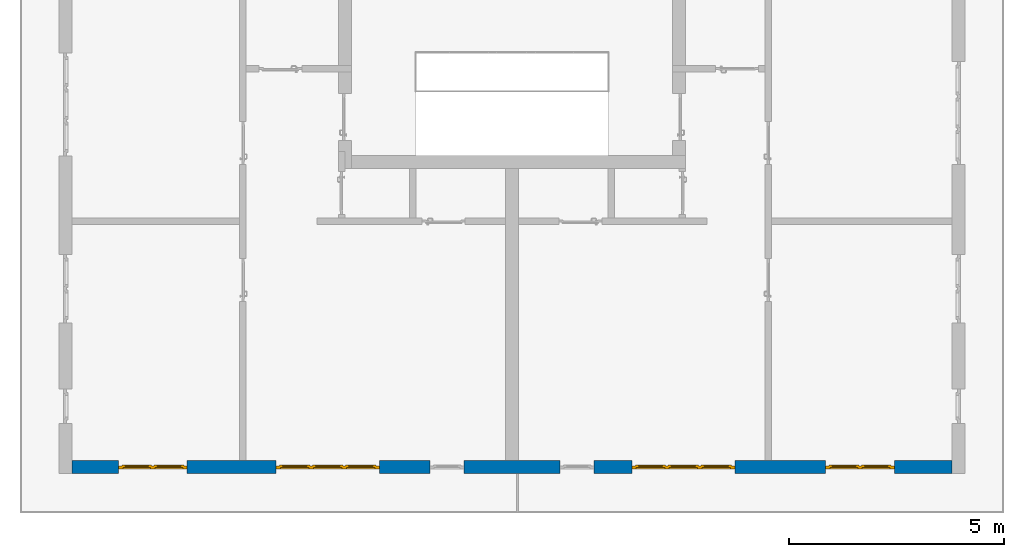
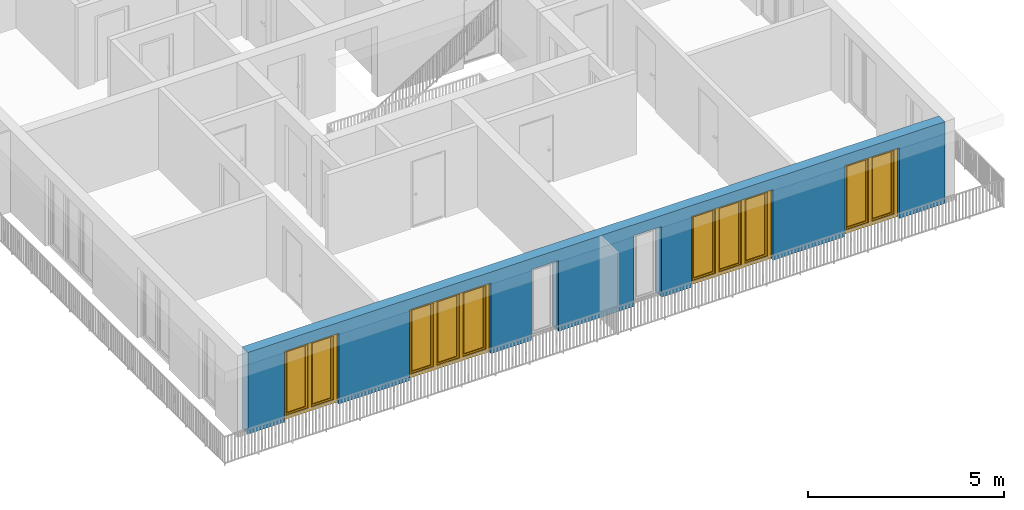
# One storey, part 9 of 54: 4 windows, 1 wall, 6 openings.
"""IFC4 building model written with IfcOpenShell, lengths in metres."""

from ifc_helpers import new_model, entity, si_unit, converted_unit, derived_unit, direction, frame, origin_with_axes, place, context, subcontext, project, spatial, polygons, source, transform, mapped, material, type_object, element, fill, save


model = new_model("IFC4")

# Units and contexts
model_context = context("Model", 3, precision=1e-05, world=origin_with_axes(), true_north=direction((0.0, 1.0)))
body_context = subcontext(model_context, "Body", "Model", "MODEL_VIEW")
ifc_project = project(units=[si_unit("LENGTHUNIT", "METRE"), si_unit("AREAUNIT", "SQUARE_METRE"), si_unit("VOLUMEUNIT", "CUBIC_METRE"), converted_unit("PLANEANGLEUNIT", "DEGREE", entity("IfcPlaneAngleMeasure", 0.0174532925199), si_unit("PLANEANGLEUNIT", "RADIAN"), dimensions=[0, 0, 0, 0, 0, 0, 0]), converted_unit("TIMEUNIT", "Year", entity("IfcTimeMeasure", 31556926.0), si_unit("TIMEUNIT", "SECOND"), dimensions=[0, 0, 1, 0, 0, 0, 0]), si_unit("MASSUNIT", "GRAM", prefix="KILO"), si_unit("THERMODYNAMICTEMPERATUREUNIT", "DEGREE_CELSIUS"), si_unit("LUMINOUSINTENSITYUNIT", "LUMEN"), si_unit("ENERGYUNIT", "JOULE", prefix="MEGA"), derived_unit("THERMALCONDUCTANCEUNIT", [(si_unit("POWERUNIT", "WATT"), 1), (si_unit("LENGTHUNIT", "METRE"), -1), (si_unit("THERMODYNAMICTEMPERATUREUNIT", "KELVIN"), -1)]), derived_unit("SPECIFICHEATCAPACITYUNIT", [(si_unit("ENERGYUNIT", "JOULE"), 1), (si_unit("MASSUNIT", "GRAM", prefix="KILO"), -1), (si_unit("THERMODYNAMICTEMPERATUREUNIT", "KELVIN"), -1)]), derived_unit("MASSDENSITYUNIT", [(si_unit("MASSUNIT", "GRAM", prefix="KILO"), 1), (si_unit("VOLUMEUNIT", "CUBIC_METRE"), -1)])], contexts=[model_context])

# Site, building, storey
site_placement = place(None, origin_with_axes())
site = spatial("IfcSite", under=ifc_project, at=site_placement, CompositionType="ELEMENT")
building_placement = place(site_placement, origin_with_axes())
building = spatial("IfcBuilding", under=site, at=building_placement, CompositionType="ELEMENT")
storey_placement = place(building_placement, frame((0.0, 0.0, 6.29), z_axis=(0.0, 0.0, 1.0), x_axis=(1.0, 0.0, 0.0)))
storey = spatial("IfcBuildingStorey", under=building, at=storey_placement, Name="2. Geschoss", CompositionType="ELEMENT", Elevation=6.29)

# Wall, openings, windows
ifc_material = material()
wall_type = type_object("IfcWallType", Name="300", PredefinedType="NOTDEFINED")
wall_placement = place(storey_placement, frame((9.3378006196, -9.92881223104, 0.0), z_axis=(0.0, 0.0, 1.0), x_axis=(-1.0, 0.0, 0.0)))
wall = element("IfcWall", 1, at=wall_placement, inside=storey, type_object=wall_type, material=ifc_material, Name="Wand-001", PredefinedType="NOTDEFINED", context=body_context, shape_type="Tessellation", body=[
    polygons([(12.4515538751, -0.3, 2.2), (12.4515538751, -0.3, 0.0), (13.63, -0.3, 0.0), (13.63, -0.3, 2.2), (16.03, -0.3, 2.2), (16.03, -0.3, 0.0), (18.0998837323, -0.3, 0.0), (18.0998837323, -0.3, 2.2), (19.6998837323, -0.3, 2.2), (19.6998837323, -0.3, 0.0), (20.78, -0.3, 0.0), (20.78, -0.3, 2.54), (0.3, -0.3, 2.54), (0.3, -0.3, 0.0), (1.6378225413, -0.3, 0.0), (1.6378225413, -0.3, 2.2), (3.2378225413, -0.3, 2.2), (3.2378225413, -0.3, 0.0), (5.35, -0.3, 0.0), (5.35, -0.3, 2.2), (7.75, -0.3, 2.2), (7.75, -0.3, 0.0), (8.62617854928, -0.3, 0.0), (8.62617854928, -0.3, 2.2), (9.42617854928, -0.3, 2.2), (9.42617854928, -0.3, 0.0), (11.6515538751, -0.3, 0.0), (11.6515538751, -0.3, 2.2), (12.4515538751, -0.1, 0.0), (12.4515538751, 0.0, 2.2), (12.4515538751, 0.0, 0.0), (13.63, 0.0, 0.0), (13.63, 0.0, 2.2), (16.03, 0.0, 2.2), (16.03, 0.0, 0.0), (18.0998837323, 0.0, 0.0), (18.0998837323, 0.0, 2.2), (19.6998837323, 0.0, 2.2), (19.6998837323, 0.0, 0.0), (20.78, 0.0, 0.0), (20.78, 0.0, 2.54), (0.3, 0.0, 2.54), (0.3, 0.0, 0.0), (1.6378225413, 0.0, 0.0), (1.6378225413, 0.0, 2.2), (3.2378225413, 0.0, 2.2), (3.2378225413, 0.0, 0.0), (5.35, 0.0, 0.0), (5.35, 0.0, 2.2), (7.75, 0.0, 2.2), (7.75, 0.0, 0.0), (8.62617854928, 0.0, 0.0), (8.62617854928, 0.0, 2.2), (9.42617854928, 0.0, 2.2), (9.42617854928, 0.0, 0.0), (11.6515538751, -0.1, 0.0), (11.6515538751, 0.0, 0.0), (11.6515538751, 0.0, 2.2)], [[[1, 2, 3, 4, 5, 6, 7, 8, 9, 10, 11, 12, 13, 14, 15, 16, 17, 18, 19, 20, 21, 22, 23, 24, 25, 26, 27, 28]], [[29, 2, 1, 30, 31]], [[2, 29, 31, 32, 3]], [[32, 33, 4, 3]], [[33, 34, 5, 4]], [[34, 35, 6, 5]], [[36, 7, 6, 35]], [[36, 37, 8, 7]], [[37, 38, 9, 8]], [[38, 39, 10, 9]], [[40, 11, 10, 39]], [[40, 41, 12, 11]], [[41, 42, 13, 12]], [[14, 13, 42, 43]], [[15, 14, 43, 44]], [[16, 15, 44, 45]], [[17, 16, 45, 46]], [[18, 17, 46, 47]], [[19, 18, 47, 48]], [[20, 19, 48, 49]], [[21, 20, 49, 50]], [[22, 21, 50, 51]], [[51, 52, 23, 22]], [[52, 53, 24, 23]], [[53, 54, 25, 24]], [[54, 55, 26, 25]], [[56, 27, 26, 55, 57]], [[28, 27, 56, 57, 58]], [[1, 28, 58, 30]], [[32, 31, 30, 58, 57, 55, 54, 53, 52, 51, 50, 49, 48, 47, 46, 45, 44, 43, 42, 41, 40, 39, 38, 37, 36, 35, 34, 33]]], closed=True),
])
opening_1_placement = place(wall_placement, frame((18.8998837323, 0.0, 0.0), z_axis=(0.0, 0.0, 1.0), x_axis=(1.0, 0.0, 0.0)))
opening_1 = element("IfcOpeningElement", 2, at=opening_1_placement, cuts=wall, Name="Fenster-001", context=body_context, identifier="Reference", shape_type="Tessellation", body=[
    polygons([(-0.8, -0.1, 0.0), (-0.8, -0.1, 2.2), (-0.8, 0.001, 2.2), (-0.8, 0.001, 0.0), (-0.8, -0.301, 0.0), (-0.8, -0.301, 2.2), (0.8, -0.1, 2.2), (0.8, 0.001, 2.2), (0.8, -0.301, 2.2), (0.8, 0.001, 0.0), (0.8, -0.1, 0.0), (0.8, -0.301, 0.0)], [[[1, 2, 3, 4]], [[2, 1, 5, 6]], [[7, 8, 3, 2, 6, 9]], [[8, 10, 4, 3]], [[1, 4, 10, 11, 12, 5]], [[6, 5, 12, 9]], [[7, 11, 10, 8]], [[11, 7, 9, 12]]], closed=True),
])
opening_2_placement = place(wall_placement, frame((2.4378225413, 0.0, 0.0), z_axis=(0.0, 0.0, 1.0), x_axis=(1.0, 0.0, 0.0)))
opening_2 = element("IfcOpeningElement", 3, at=opening_2_placement, cuts=wall, Name="Fenster-002", context=body_context, identifier="Reference", shape_type="Tessellation", body=[
    polygons([(-0.8, -0.1, 0.0), (-0.8, -0.1, 2.2), (-0.8, 0.000999999999999, 2.2), (-0.8, 0.000999999999999, 0.0), (-0.8, -0.301, 0.0), (-0.8, -0.301, 2.2), (0.8, -0.1, 2.2), (0.8, 0.000999999999999, 2.2), (0.8, -0.301, 2.2), (0.8, 0.000999999999999, 0.0), (0.8, -0.1, 0.0), (0.8, -0.301, 0.0)], [[[1, 2, 3, 4]], [[2, 1, 5, 6]], [[7, 8, 3, 2, 6, 9]], [[8, 10, 4, 3]], [[1, 4, 10, 11, 12, 5]], [[6, 5, 12, 9]], [[7, 11, 10, 8]], [[11, 7, 9, 12]]], closed=True),
])
opening_3_placement = place(wall_placement, frame((14.83, 0.0, 0.0), z_axis=(0.0, 0.0, 1.0), x_axis=(1.0, 0.0, 0.0)))
opening_3 = element("IfcOpeningElement", 4, at=opening_3_placement, cuts=wall, Name="Fenster-002", context=body_context, identifier="Reference", shape_type="Tessellation", body=[
    polygons([(-1.2, -0.1, 0.0), (-1.2, -0.1, 2.2), (-1.2, 0.001, 2.2), (-1.2, 0.001, 0.0), (-1.2, -0.301, 0.0), (-1.2, -0.301, 2.2), (1.2, -0.1, 2.2), (1.2, 0.001, 2.2), (1.2, -0.301, 2.2), (1.2, 0.001, 0.0), (1.2, -0.1, 0.0), (1.2, -0.301, 0.0)], [[[1, 2, 3, 4]], [[2, 1, 5, 6]], [[7, 8, 3, 2, 6, 9]], [[8, 10, 4, 3]], [[1, 4, 10, 11, 12, 5]], [[6, 5, 12, 9]], [[7, 11, 10, 8]], [[11, 7, 9, 12]]], closed=True),
])
opening_4_placement = place(wall_placement, frame((6.55, 0.0, 0.0), z_axis=(0.0, 0.0, 1.0), x_axis=(1.0, 0.0, 0.0)))
opening_4 = element("IfcOpeningElement", 5, at=opening_4_placement, cuts=wall, Name="Fenster-003", context=body_context, identifier="Reference", shape_type="Tessellation", body=[
    polygons([(-1.2, -0.1, 0.0), (-1.2, -0.1, 2.2), (-1.2, 0.000999999999999, 2.2), (-1.2, 0.000999999999999, 0.0), (-1.2, -0.301, 0.0), (-1.2, -0.301, 2.2), (1.2, -0.1, 2.2), (1.2, 0.001, 2.2), (1.2, -0.301, 2.2), (1.2, 0.001, 0.0), (1.2, -0.1, 0.0), (1.2, -0.301, 0.0)], [[[1, 2, 3, 4]], [[2, 1, 5, 6]], [[7, 8, 3, 2, 6, 9]], [[8, 10, 4, 3]], [[1, 4, 10, 11, 12, 5]], [[6, 5, 12, 9]], [[7, 11, 10, 8]], [[11, 7, 9, 12]]], closed=True),
])
opening_5_placement = place(wall_placement, frame((9.02617854928, 0.0, 0.0), z_axis=(0.0, 0.0, 1.0), x_axis=(1.0, 0.0, 0.0)))
element("IfcOpeningElement", 6, at=opening_5_placement, cuts=wall, Name="Fenster-003", context=body_context, identifier="Reference", shape_type="Tessellation", body=[
    polygons([(-0.4, -0.1, 0.0), (-0.4, -0.1, 2.2), (-0.4, 0.001, 2.2), (-0.4, 0.001, 0.0), (-0.4, -0.301, 0.0), (-0.4, -0.301, 2.2), (0.4, -0.1, 2.2), (0.4, 0.001, 2.2), (0.4, -0.301, 2.2), (0.4, 0.001, 0.0), (0.4, -0.1, 0.0), (0.4, -0.301, 0.0)], [[[1, 2, 3, 4]], [[2, 1, 5, 6]], [[7, 8, 3, 2, 6, 9]], [[8, 10, 4, 3]], [[1, 4, 10, 11, 12, 5]], [[6, 5, 12, 9]], [[7, 11, 10, 8]], [[11, 7, 9, 12]]], closed=True),
])
opening_6_placement = place(wall_placement, frame((12.0515538751, 0.0, 0.0), z_axis=(0.0, 0.0, 1.0), x_axis=(1.0, 0.0, 0.0)))
element("IfcOpeningElement", 7, at=opening_6_placement, cuts=wall, Name="Fenster-003", context=body_context, identifier="Reference", shape_type="Tessellation", body=[
    polygons([(-0.4, -0.1, 0.0), (-0.4, -0.1, 2.2), (-0.4, 0.001, 2.2), (-0.4, 0.001, 0.0), (-0.4, -0.301, 0.0), (-0.4, -0.301, 2.2), (0.4, -0.1, 2.2), (0.4, 0.001, 2.2), (0.4, -0.301, 2.2), (0.4, 0.001, 0.0), (0.4, -0.1, 0.0), (0.4, -0.301, 0.0)], [[[1, 2, 3, 4]], [[2, 1, 5, 6]], [[7, 8, 3, 2, 6, 9]], [[8, 10, 4, 3]], [[1, 4, 10, 11, 12, 5]], [[6, 5, 12, 9]], [[7, 11, 10, 8]], [[11, 7, 9, 12]]], closed=True),
])
window_type_1 = type_object("IfcWindowType", Name="2-1+1 26", PartitioningType="DOUBLE_PANEL_VERTICAL", PredefinedType="WINDOW")
shared_shape_1 = source(origin_with_axes(), body_context, "Body", "Tessellation", [
    polygons([(-0.8, -0.07, 0.0), (-0.8, 0.0, 0.0), (-0.7, 0.0, 0.1), (-0.7, -0.07, 0.1), (-0.8, -0.07, 2.2), (-0.8, 0.0, 2.2), (-0.7, 0.0, 2.1), (-0.7, -0.07, 2.1)], [[[1, 2, 3, 4]], [[5, 6, 2, 1]], [[2, 6, 7, 3]], [[4, 3, 7, 8]], [[1, 4, 8, 5]], [[8, 7, 6, 5]]], closed=True),
    polygons([(0.8, -0.07, 0.0), (0.8, 0.0, 0.0), (0.8, 0.0, 2.2), (0.8, -0.07, 2.2), (0.7, -0.07, 0.1), (0.7, 0.0, 0.1), (0.7, 0.0, 2.1), (0.7, -0.07, 2.1)], [[[1, 2, 3, 4]], [[5, 6, 2, 1]], [[2, 6, 7, 3]], [[4, 3, 7, 8]], [[1, 4, 8, 5]], [[8, 7, 6, 5]]], closed=True),
    polygons([(-0.8, -0.07, 0.0), (-0.8, 0.0, 0.0), (0.8, 0.0, 0.0), (0.8, -0.07, 0.0), (-0.7, -0.07, 0.1), (-0.7, 0.0, 0.1), (-0.05, 0.0, 0.1), (0.05, 0.0, 0.1), (0.7, 0.0, 0.1), (0.7, -0.07, 0.1), (0.05, -0.07, 0.1), (-0.05, -0.07, 0.1)], [[[1, 2, 3, 4]], [[5, 6, 2, 1]], [[2, 6, 7, 8, 9, 3]], [[4, 3, 9, 10]], [[1, 4, 10, 11, 12, 5]], [[12, 7, 6, 5]], [[11, 8, 7, 12]], [[10, 9, 8, 11]]], closed=True),
    polygons([(-0.8, -0.07, 2.2), (-0.8, 0.0, 2.2), (-0.7, 0.0, 2.1), (-0.7, -0.07, 2.1), (0.8, -0.07, 2.2), (0.8, 0.0, 2.2), (0.7, 0.0, 2.1), (0.05, 0.0, 2.1), (-0.05, 0.0, 2.1), (-0.05, -0.07, 2.1), (0.05, -0.07, 2.1), (0.7, -0.07, 2.1)], [[[1, 2, 3, 4]], [[5, 6, 2, 1]], [[2, 6, 7, 8, 9, 3]], [[4, 3, 9, 10]], [[1, 4, 10, 11, 12, 5]], [[12, 7, 6, 5]], [[11, 8, 7, 12]], [[10, 9, 8, 11]]], closed=True),
    polygons([(-0.05, -0.07, 0.1), (-0.05, 0.0, 0.1), (0.05, 0.0, 0.1), (0.05, -0.07, 0.1), (-0.05, -0.07, 2.1), (-0.05, 0.0, 2.1), (0.05, 0.0, 2.1), (0.05, -0.07, 2.1)], [[[1, 2, 3, 4]], [[5, 6, 2, 1]], [[2, 6, 7, 3]], [[4, 3, 7, 8]], [[1, 4, 8, 5]], [[8, 7, 6, 5]]], closed=True),
    polygons([(-0.72, 0.0, 0.08), (-0.72, 0.03, 0.08), (-0.65, 0.03, 0.15), (-0.65, 0.0, 0.15), (-0.72, 0.0, 2.12), (-0.72, 0.03, 2.12), (-0.65, 0.03, 2.05), (-0.65, 0.0, 2.05)], [[[1, 2, 3, 4]], [[5, 6, 2, 1]], [[2, 6, 7, 3]], [[4, 3, 7, 8]], [[1, 4, 8, 5]], [[8, 7, 6, 5]]], closed=True),
    polygons([(-0.03, 0.0, 0.08), (-0.1, 0.0, 0.15), (-0.1, 0.03, 0.15), (-0.03, 0.03, 0.08), (-0.03, 0.0, 2.12), (-0.1, 0.0, 2.05), (-0.1, 0.03, 2.05), (-0.03, 0.03, 2.12)], [[[1, 2, 3, 4]], [[1, 5, 6, 2]], [[2, 6, 7, 3]], [[4, 3, 7, 8]], [[5, 1, 4, 8]], [[6, 5, 8, 7]]], closed=True),
    polygons([(-0.72, 0.0, 0.08), (-0.72, 0.03, 0.08), (-0.03, 0.03, 0.08), (-0.03, 0.0, 0.08), (-0.65, 0.0, 0.15), (-0.65, 0.03, 0.15), (-0.1, 0.03, 0.15), (-0.1, 0.0, 0.15)], [[[1, 2, 3, 4]], [[5, 6, 2, 1]], [[2, 6, 7, 3]], [[4, 3, 7, 8]], [[1, 4, 8, 5]], [[8, 7, 6, 5]]], closed=True),
    polygons([(-0.72, 0.0, 2.12), (-0.03, 0.0, 2.12), (-0.03, 0.03, 2.12), (-0.72, 0.03, 2.12), (-0.65, 0.0, 2.05), (-0.1, 0.0, 2.05), (-0.1, 0.03, 2.05), (-0.65, 0.03, 2.05)], [[[1, 2, 3, 4]], [[1, 5, 6, 2]], [[2, 6, 7, 3]], [[4, 3, 7, 8]], [[5, 1, 4, 8]], [[6, 5, 8, 7]]], closed=True),
    polygons([(-0.7, -0.03, 0.1), (-0.7, 0.0, 0.1), (-0.65, 0.0, 0.15), (-0.65, -0.03, 0.15), (-0.7, -0.03, 2.1), (-0.7, 0.0, 2.1), (-0.65, 0.0, 2.05), (-0.65, -0.03, 2.05)], [[[1, 2, 3, 4]], [[5, 6, 2, 1]], [[2, 6, 7, 3]], [[4, 3, 7, 8]], [[1, 4, 8, 5]], [[8, 7, 6, 5]]], closed=True),
    polygons([(-0.05, -0.03, 0.1), (-0.1, -0.03, 0.15), (-0.1, 0.0, 0.15), (-0.05, 0.0, 0.1), (-0.05, -0.03, 2.1), (-0.1, -0.03, 2.05), (-0.1, 0.0, 2.05), (-0.05, 0.0, 2.1)], [[[1, 2, 3, 4]], [[1, 5, 6, 2]], [[2, 6, 7, 3]], [[4, 3, 7, 8]], [[5, 1, 4, 8]], [[6, 5, 8, 7]]], closed=True),
    polygons([(-0.7, -0.03, 0.1), (-0.7, 0.0, 0.1), (-0.05, 0.0, 0.1), (-0.05, -0.03, 0.1), (-0.65, -0.03, 0.15), (-0.65, 0.0, 0.15), (-0.1, 0.0, 0.15), (-0.1, -0.03, 0.15)], [[[1, 2, 3, 4]], [[5, 6, 2, 1]], [[2, 6, 7, 3]], [[4, 3, 7, 8]], [[1, 4, 8, 5]], [[8, 7, 6, 5]]], closed=True),
    polygons([(-0.7, -0.03, 2.1), (-0.05, -0.03, 2.1), (-0.05, 0.0, 2.1), (-0.7, 0.0, 2.1), (-0.65, -0.03, 2.05), (-0.1, -0.03, 2.05), (-0.1, 0.0, 2.05), (-0.65, 0.0, 2.05)], [[[1, 2, 3, 4]], [[1, 5, 6, 2]], [[2, 6, 7, 3]], [[4, 3, 7, 8]], [[5, 1, 4, 8]], [[6, 5, 8, 7]]], closed=True),
    polygons([(-0.65, -0.005, 0.15), (-0.65, 0.005, 0.15), (-0.1, 0.005, 0.15), (-0.1, -0.005, 0.15), (-0.65, -0.005, 2.05), (-0.65, 0.005, 2.05), (-0.1, 0.005, 2.05), (-0.1, -0.005, 2.05)], [[[1, 2, 3, 4]], [[5, 6, 2, 1]], [[2, 6, 7, 3]], [[4, 3, 7, 8]], [[1, 4, 8, 5]], [[8, 7, 6, 5]]], closed=True),
    polygons([(0.03, 0.0, 0.08), (0.03, 0.03, 0.08), (0.1, 0.03, 0.15), (0.1, 0.0, 0.15), (0.03, 0.0, 2.12), (0.03, 0.03, 2.12), (0.1, 0.03, 2.05), (0.1, 0.0, 2.05)], [[[1, 2, 3, 4]], [[5, 6, 2, 1]], [[2, 6, 7, 3]], [[4, 3, 7, 8]], [[1, 4, 8, 5]], [[8, 7, 6, 5]]], closed=True),
    polygons([(0.72, 0.0, 0.08), (0.65, 0.0, 0.15), (0.65, 0.03, 0.15), (0.72, 0.03, 0.08), (0.72, 0.0, 2.12), (0.65, 0.0, 2.05), (0.65, 0.03, 2.05), (0.72, 0.03, 2.12)], [[[1, 2, 3, 4]], [[1, 5, 6, 2]], [[2, 6, 7, 3]], [[4, 3, 7, 8]], [[5, 1, 4, 8]], [[6, 5, 8, 7]]], closed=True),
    polygons([(0.03, 0.0, 0.08), (0.03, 0.03, 0.08), (0.72, 0.03, 0.08), (0.72, 0.0, 0.08), (0.1, 0.0, 0.15), (0.1, 0.03, 0.15), (0.65, 0.03, 0.15), (0.65, 0.0, 0.15)], [[[1, 2, 3, 4]], [[5, 6, 2, 1]], [[2, 6, 7, 3]], [[4, 3, 7, 8]], [[1, 4, 8, 5]], [[8, 7, 6, 5]]], closed=True),
    polygons([(0.03, 0.0, 2.12), (0.72, 0.0, 2.12), (0.72, 0.03, 2.12), (0.03, 0.03, 2.12), (0.1, 0.0, 2.05), (0.65, 0.0, 2.05), (0.65, 0.03, 2.05), (0.1, 0.03, 2.05)], [[[1, 2, 3, 4]], [[1, 5, 6, 2]], [[2, 6, 7, 3]], [[4, 3, 7, 8]], [[5, 1, 4, 8]], [[6, 5, 8, 7]]], closed=True),
    polygons([(0.05, -0.03, 0.1), (0.05, 0.0, 0.1), (0.1, 0.0, 0.15), (0.1, -0.03, 0.15), (0.05, -0.03, 2.1), (0.05, 0.0, 2.1), (0.1, 0.0, 2.05), (0.1, -0.03, 2.05)], [[[1, 2, 3, 4]], [[5, 6, 2, 1]], [[2, 6, 7, 3]], [[4, 3, 7, 8]], [[1, 4, 8, 5]], [[8, 7, 6, 5]]], closed=True),
    polygons([(0.7, -0.03, 0.1), (0.65, -0.03, 0.15), (0.65, 0.0, 0.15), (0.7, 0.0, 0.1), (0.7, -0.03, 2.1), (0.65, -0.03, 2.05), (0.65, 0.0, 2.05), (0.7, 0.0, 2.1)], [[[1, 2, 3, 4]], [[1, 5, 6, 2]], [[2, 6, 7, 3]], [[4, 3, 7, 8]], [[5, 1, 4, 8]], [[6, 5, 8, 7]]], closed=True),
    polygons([(0.05, -0.03, 0.1), (0.05, 0.0, 0.1), (0.7, 0.0, 0.1), (0.7, -0.03, 0.1), (0.1, -0.03, 0.15), (0.1, 0.0, 0.15), (0.65, 0.0, 0.15), (0.65, -0.03, 0.15)], [[[1, 2, 3, 4]], [[5, 6, 2, 1]], [[2, 6, 7, 3]], [[4, 3, 7, 8]], [[1, 4, 8, 5]], [[8, 7, 6, 5]]], closed=True),
    polygons([(0.05, -0.03, 2.1), (0.7, -0.03, 2.1), (0.7, 0.0, 2.1), (0.05, 0.0, 2.1), (0.1, -0.03, 2.05), (0.65, -0.03, 2.05), (0.65, 0.0, 2.05), (0.1, 0.0, 2.05)], [[[1, 2, 3, 4]], [[1, 5, 6, 2]], [[2, 6, 7, 3]], [[4, 3, 7, 8]], [[5, 1, 4, 8]], [[6, 5, 8, 7]]], closed=True),
    polygons([(0.1, -0.005, 0.15), (0.1, 0.005, 0.15), (0.65, 0.005, 0.15), (0.65, -0.005, 0.15), (0.1, -0.005, 2.05), (0.1, 0.005, 2.05), (0.65, 0.005, 2.05), (0.65, -0.005, 2.05)], [[[1, 2, 3, 4]], [[5, 6, 2, 1]], [[2, 6, 7, 3]], [[4, 3, 7, 8]], [[1, 4, 8, 5]], [[8, 7, 6, 5]]], closed=True),
])
window_1_placement = place(opening_1_placement, frame((0.8, 0.0, 0.0), z_axis=(0.0, 0.0, 1.0), x_axis=(-1.0, 0.0, 0.0)))
window_1 = element("IfcWindow", 8, at=window_1_placement, inside=storey, type_object=window_type_1, Name="Fenster-001", OverallHeight=2.2, OverallWidth=1.6, PredefinedType="WINDOW", context=body_context, shape_type="MappedRepresentation", body=[
    mapped(shared_shape_1, transform((0.8, 0.17, 0.0))),
])
fill(opening_1, window_1)
window_2_placement = place(opening_2_placement, frame((0.8, 0.0, 0.0), z_axis=(0.0, 0.0, 1.0), x_axis=(-1.0, 0.0, 0.0)))
window_2 = element("IfcWindow", 9, at=window_2_placement, inside=storey, type_object=window_type_1, Name="Fenster-002", OverallHeight=2.2, OverallWidth=1.6, PredefinedType="WINDOW", context=body_context, shape_type="MappedRepresentation", body=[
    mapped(shared_shape_1, transform((0.8, 0.17, 0.0))),
])
fill(opening_2, window_2)
window_type_2 = type_object("IfcWindowType", Name="3-1+1+1 26", PartitioningType="TRIPLE_PANEL_VERTICAL", PredefinedType="WINDOW")
shared_shape_2 = source(origin_with_axes(), body_context, "Body", "Tessellation", [
    polygons([(-1.2, -0.07, 0.0), (-1.2, 0.0, 0.0), (-1.1, 0.0, 0.1), (-1.1, -0.07, 0.1), (-1.2, -0.07, 2.2), (-1.2, 0.0, 2.2), (-1.1, 0.0, 2.1), (-1.1, -0.07, 2.1)], [[[1, 2, 3, 4]], [[5, 6, 2, 1]], [[2, 6, 7, 3]], [[4, 3, 7, 8]], [[1, 4, 8, 5]], [[8, 7, 6, 5]]], closed=True),
    polygons([(1.2, -0.07, 0.0), (1.2, 0.0, 0.0), (1.2, 0.0, 2.2), (1.2, -0.07, 2.2), (1.1, -0.07, 0.1), (1.1, 0.0, 0.1), (1.1, 0.0, 2.1), (1.1, -0.07, 2.1)], [[[1, 2, 3, 4]], [[5, 6, 2, 1]], [[2, 6, 7, 3]], [[4, 3, 7, 8]], [[1, 4, 8, 5]], [[8, 7, 6, 5]]], closed=True),
    polygons([(-1.2, -0.07, 0.0), (-1.2, 0.0, 0.0), (1.2, 0.0, 0.0), (1.2, -0.07, 0.0), (-1.1, -0.07, 0.1), (-1.1, 0.0, 0.1), (-0.433333333333, 0.0, 0.1), (-0.333333333333, 0.0, 0.1), (0.333333333333, 0.0, 0.1), (0.433333333333, 0.0, 0.1), (1.1, 0.0, 0.1), (1.1, -0.07, 0.1), (0.433333333333, -0.07, 0.1), (0.333333333333, -0.07, 0.1), (-0.333333333333, -0.07, 0.1), (-0.433333333333, -0.07, 0.1)], [[[1, 2, 3, 4]], [[5, 6, 2, 1]], [[2, 6, 7, 8, 9, 10, 11, 3]], [[4, 3, 11, 12]], [[1, 4, 12, 13, 14, 15, 16, 5]], [[16, 7, 6, 5]], [[15, 8, 7, 16]], [[14, 9, 8, 15]], [[13, 10, 9, 14]], [[12, 11, 10, 13]]], closed=True),
    polygons([(-1.2, -0.07, 2.2), (-1.2, 0.0, 2.2), (-1.1, 0.0, 2.1), (-1.1, -0.07, 2.1), (1.2, -0.07, 2.2), (1.2, 0.0, 2.2), (1.1, 0.0, 2.1), (0.433333333333, 0.0, 2.1), (0.333333333333, 0.0, 2.1), (-0.333333333333, 0.0, 2.1), (-0.433333333333, 0.0, 2.1), (-0.433333333333, -0.07, 2.1), (-0.333333333333, -0.07, 2.1), (0.333333333333, -0.07, 2.1), (0.433333333333, -0.07, 2.1), (1.1, -0.07, 2.1)], [[[1, 2, 3, 4]], [[5, 6, 2, 1]], [[2, 6, 7, 8, 9, 10, 11, 3]], [[4, 3, 11, 12]], [[1, 4, 12, 13, 14, 15, 16, 5]], [[16, 7, 6, 5]], [[15, 8, 7, 16]], [[14, 9, 8, 15]], [[13, 10, 9, 14]], [[12, 11, 10, 13]]], closed=True),
    polygons([(0.333333333333, -0.07, 0.1), (0.333333333333, 0.0, 0.1), (0.433333333333, 0.0, 0.1), (0.433333333333, -0.07, 0.1), (0.333333333333, -0.07, 2.1), (0.333333333333, 0.0, 2.1), (0.433333333333, 0.0, 2.1), (0.433333333333, -0.07, 2.1)], [[[1, 2, 3, 4]], [[5, 6, 2, 1]], [[2, 6, 7, 3]], [[4, 3, 7, 8]], [[1, 4, 8, 5]], [[8, 7, 6, 5]]], closed=True),
    polygons([(-0.433333333333, -0.07, 0.1), (-0.433333333333, 0.0, 0.1), (-0.333333333333, 0.0, 0.1), (-0.333333333333, -0.07, 0.1), (-0.433333333333, -0.07, 2.1), (-0.433333333333, 0.0, 2.1), (-0.333333333333, 0.0, 2.1), (-0.333333333333, -0.07, 2.1)], [[[1, 2, 3, 4]], [[5, 6, 2, 1]], [[2, 6, 7, 3]], [[4, 3, 7, 8]], [[1, 4, 8, 5]], [[8, 7, 6, 5]]], closed=True),
    polygons([(-1.12, 0.0, 0.08), (-1.12, 0.03, 0.08), (-1.05, 0.03, 0.15), (-1.05, 0.0, 0.15), (-1.12, 0.0, 2.12), (-1.12, 0.03, 2.12), (-1.05, 0.03, 2.05), (-1.05, 0.0, 2.05)], [[[1, 2, 3, 4]], [[5, 6, 2, 1]], [[2, 6, 7, 3]], [[4, 3, 7, 8]], [[1, 4, 8, 5]], [[8, 7, 6, 5]]], closed=True),
    polygons([(-0.413333333333, 0.0, 0.08), (-0.483333333333, 0.0, 0.15), (-0.483333333333, 0.03, 0.15), (-0.413333333333, 0.03, 0.08), (-0.413333333333, 0.0, 2.12), (-0.483333333333, 0.0, 2.05), (-0.483333333333, 0.03, 2.05), (-0.413333333333, 0.03, 2.12)], [[[1, 2, 3, 4]], [[1, 5, 6, 2]], [[2, 6, 7, 3]], [[4, 3, 7, 8]], [[5, 1, 4, 8]], [[6, 5, 8, 7]]], closed=True),
    polygons([(-1.12, 0.0, 0.08), (-1.12, 0.03, 0.08), (-0.413333333333, 0.03, 0.08), (-0.413333333333, 0.0, 0.08), (-1.05, 0.0, 0.15), (-1.05, 0.03, 0.15), (-0.483333333333, 0.03, 0.15), (-0.483333333333, 0.0, 0.15)], [[[1, 2, 3, 4]], [[5, 6, 2, 1]], [[2, 6, 7, 3]], [[4, 3, 7, 8]], [[1, 4, 8, 5]], [[8, 7, 6, 5]]], closed=True),
    polygons([(-1.12, 0.0, 2.12), (-0.413333333333, 0.0, 2.12), (-0.413333333333, 0.03, 2.12), (-1.12, 0.03, 2.12), (-1.05, 0.0, 2.05), (-0.483333333333, 0.0, 2.05), (-0.483333333333, 0.03, 2.05), (-1.05, 0.03, 2.05)], [[[1, 2, 3, 4]], [[1, 5, 6, 2]], [[2, 6, 7, 3]], [[4, 3, 7, 8]], [[5, 1, 4, 8]], [[6, 5, 8, 7]]], closed=True),
    polygons([(-1.1, -0.03, 0.1), (-1.1, 0.0, 0.1), (-1.05, 0.0, 0.15), (-1.05, -0.03, 0.15), (-1.1, -0.03, 2.1), (-1.1, 0.0, 2.1), (-1.05, 0.0, 2.05), (-1.05, -0.03, 2.05)], [[[1, 2, 3, 4]], [[5, 6, 2, 1]], [[2, 6, 7, 3]], [[4, 3, 7, 8]], [[1, 4, 8, 5]], [[8, 7, 6, 5]]], closed=True),
    polygons([(-0.433333333333, -0.03, 0.1), (-0.483333333333, -0.03, 0.15), (-0.483333333333, 0.0, 0.15), (-0.433333333333, 0.0, 0.1), (-0.433333333333, -0.03, 2.1), (-0.483333333333, -0.03, 2.05), (-0.483333333333, 0.0, 2.05), (-0.433333333333, 0.0, 2.1)], [[[1, 2, 3, 4]], [[1, 5, 6, 2]], [[2, 6, 7, 3]], [[4, 3, 7, 8]], [[5, 1, 4, 8]], [[6, 5, 8, 7]]], closed=True),
    polygons([(-1.1, -0.03, 0.1), (-1.1, 0.0, 0.1), (-0.433333333333, 0.0, 0.1), (-0.433333333333, -0.03, 0.1), (-1.05, -0.03, 0.15), (-1.05, 0.0, 0.15), (-0.483333333333, 0.0, 0.15), (-0.483333333333, -0.03, 0.15)], [[[1, 2, 3, 4]], [[5, 6, 2, 1]], [[2, 6, 7, 3]], [[4, 3, 7, 8]], [[1, 4, 8, 5]], [[8, 7, 6, 5]]], closed=True),
    polygons([(-1.1, -0.03, 2.1), (-0.433333333333, -0.03, 2.1), (-0.433333333333, 0.0, 2.1), (-1.1, 0.0, 2.1), (-1.05, -0.03, 2.05), (-0.483333333333, -0.03, 2.05), (-0.483333333333, 0.0, 2.05), (-1.05, 0.0, 2.05)], [[[1, 2, 3, 4]], [[1, 5, 6, 2]], [[2, 6, 7, 3]], [[4, 3, 7, 8]], [[5, 1, 4, 8]], [[6, 5, 8, 7]]], closed=True),
    polygons([(-1.05, -0.005, 0.15), (-1.05, 0.005, 0.15), (-0.483333333333, 0.005, 0.15), (-0.483333333333, -0.005, 0.15), (-1.05, -0.005, 2.05), (-1.05, 0.005, 2.05), (-0.483333333333, 0.005, 2.05), (-0.483333333333, -0.005, 2.05)], [[[1, 2, 3, 4]], [[5, 6, 2, 1]], [[2, 6, 7, 3]], [[4, 3, 7, 8]], [[1, 4, 8, 5]], [[8, 7, 6, 5]]], closed=True),
    polygons([(-0.353333333333, 0.0, 0.08), (-0.353333333333, 0.03, 0.08), (-0.283333333333, 0.03, 0.15), (-0.283333333333, 0.0, 0.15), (-0.353333333333, 0.0, 2.12), (-0.353333333333, 0.03, 2.12), (-0.283333333333, 0.03, 2.05), (-0.283333333333, 0.0, 2.05)], [[[1, 2, 3, 4]], [[5, 6, 2, 1]], [[2, 6, 7, 3]], [[4, 3, 7, 8]], [[1, 4, 8, 5]], [[8, 7, 6, 5]]], closed=True),
    polygons([(0.353333333333, 0.0, 0.08), (0.283333333333, 0.0, 0.15), (0.283333333333, 0.03, 0.15), (0.353333333333, 0.03, 0.08), (0.353333333333, 0.0, 2.12), (0.283333333333, 0.0, 2.05), (0.283333333333, 0.03, 2.05), (0.353333333333, 0.03, 2.12)], [[[1, 2, 3, 4]], [[1, 5, 6, 2]], [[2, 6, 7, 3]], [[4, 3, 7, 8]], [[5, 1, 4, 8]], [[6, 5, 8, 7]]], closed=True),
    polygons([(-0.353333333333, 0.0, 0.08), (-0.353333333333, 0.03, 0.08), (0.353333333333, 0.03, 0.08), (0.353333333333, 0.0, 0.08), (-0.283333333333, 0.0, 0.15), (-0.283333333333, 0.03, 0.15), (0.283333333333, 0.03, 0.15), (0.283333333333, 0.0, 0.15)], [[[1, 2, 3, 4]], [[5, 6, 2, 1]], [[2, 6, 7, 3]], [[4, 3, 7, 8]], [[1, 4, 8, 5]], [[8, 7, 6, 5]]], closed=True),
    polygons([(-0.353333333333, 0.0, 2.12), (0.353333333333, 0.0, 2.12), (0.353333333333, 0.03, 2.12), (-0.353333333333, 0.03, 2.12), (-0.283333333333, 0.0, 2.05), (0.283333333333, 0.0, 2.05), (0.283333333333, 0.03, 2.05), (-0.283333333333, 0.03, 2.05)], [[[1, 2, 3, 4]], [[1, 5, 6, 2]], [[2, 6, 7, 3]], [[4, 3, 7, 8]], [[5, 1, 4, 8]], [[6, 5, 8, 7]]], closed=True),
    polygons([(-0.333333333333, -0.03, 0.1), (-0.333333333333, 0.0, 0.1), (-0.283333333333, 0.0, 0.15), (-0.283333333333, -0.03, 0.15), (-0.333333333333, -0.03, 2.1), (-0.333333333333, 0.0, 2.1), (-0.283333333333, 0.0, 2.05), (-0.283333333333, -0.03, 2.05)], [[[1, 2, 3, 4]], [[5, 6, 2, 1]], [[2, 6, 7, 3]], [[4, 3, 7, 8]], [[1, 4, 8, 5]], [[8, 7, 6, 5]]], closed=True),
    polygons([(0.333333333333, -0.03, 0.1), (0.283333333333, -0.03, 0.15), (0.283333333333, 0.0, 0.15), (0.333333333333, 0.0, 0.1), (0.333333333333, -0.03, 2.1), (0.283333333333, -0.03, 2.05), (0.283333333333, 0.0, 2.05), (0.333333333333, 0.0, 2.1)], [[[1, 2, 3, 4]], [[1, 5, 6, 2]], [[2, 6, 7, 3]], [[4, 3, 7, 8]], [[5, 1, 4, 8]], [[6, 5, 8, 7]]], closed=True),
    polygons([(-0.333333333333, -0.03, 0.1), (-0.333333333333, 0.0, 0.1), (0.333333333333, 0.0, 0.1), (0.333333333333, -0.03, 0.1), (-0.283333333333, -0.03, 0.15), (-0.283333333333, 0.0, 0.15), (0.283333333333, 0.0, 0.15), (0.283333333333, -0.03, 0.15)], [[[1, 2, 3, 4]], [[5, 6, 2, 1]], [[2, 6, 7, 3]], [[4, 3, 7, 8]], [[1, 4, 8, 5]], [[8, 7, 6, 5]]], closed=True),
    polygons([(-0.333333333333, -0.03, 2.1), (0.333333333333, -0.03, 2.1), (0.333333333333, 0.0, 2.1), (-0.333333333333, 0.0, 2.1), (-0.283333333333, -0.03, 2.05), (0.283333333333, -0.03, 2.05), (0.283333333333, 0.0, 2.05), (-0.283333333333, 0.0, 2.05)], [[[1, 2, 3, 4]], [[1, 5, 6, 2]], [[2, 6, 7, 3]], [[4, 3, 7, 8]], [[5, 1, 4, 8]], [[6, 5, 8, 7]]], closed=True),
    polygons([(-0.283333333333, -0.005, 0.15), (-0.283333333333, 0.005, 0.15), (0.283333333333, 0.005, 0.15), (0.283333333333, -0.005, 0.15), (-0.283333333333, -0.005, 2.05), (-0.283333333333, 0.005, 2.05), (0.283333333333, 0.005, 2.05), (0.283333333333, -0.005, 2.05)], [[[1, 2, 3, 4]], [[5, 6, 2, 1]], [[2, 6, 7, 3]], [[4, 3, 7, 8]], [[1, 4, 8, 5]], [[8, 7, 6, 5]]], closed=True),
    polygons([(0.413333333333, 0.0, 0.08), (0.413333333333, 0.03, 0.08), (0.483333333333, 0.03, 0.15), (0.483333333333, 0.0, 0.15), (0.413333333333, 0.0, 2.12), (0.413333333333, 0.03, 2.12), (0.483333333333, 0.03, 2.05), (0.483333333333, 0.0, 2.05)], [[[1, 2, 3, 4]], [[5, 6, 2, 1]], [[2, 6, 7, 3]], [[4, 3, 7, 8]], [[1, 4, 8, 5]], [[8, 7, 6, 5]]], closed=True),
    polygons([(1.12, 0.0, 0.08), (1.05, 0.0, 0.15), (1.05, 0.03, 0.15), (1.12, 0.03, 0.08), (1.12, 0.0, 2.12), (1.05, 0.0, 2.05), (1.05, 0.03, 2.05), (1.12, 0.03, 2.12)], [[[1, 2, 3, 4]], [[1, 5, 6, 2]], [[2, 6, 7, 3]], [[4, 3, 7, 8]], [[5, 1, 4, 8]], [[6, 5, 8, 7]]], closed=True),
    polygons([(0.413333333333, 0.0, 0.08), (0.413333333333, 0.03, 0.08), (1.12, 0.03, 0.08), (1.12, 0.0, 0.08), (0.483333333333, 0.0, 0.15), (0.483333333333, 0.03, 0.15), (1.05, 0.03, 0.15), (1.05, 0.0, 0.15)], [[[1, 2, 3, 4]], [[5, 6, 2, 1]], [[2, 6, 7, 3]], [[4, 3, 7, 8]], [[1, 4, 8, 5]], [[8, 7, 6, 5]]], closed=True),
    polygons([(0.413333333333, 0.0, 2.12), (1.12, 0.0, 2.12), (1.12, 0.03, 2.12), (0.413333333333, 0.03, 2.12), (0.483333333333, 0.0, 2.05), (1.05, 0.0, 2.05), (1.05, 0.03, 2.05), (0.483333333333, 0.03, 2.05)], [[[1, 2, 3, 4]], [[1, 5, 6, 2]], [[2, 6, 7, 3]], [[4, 3, 7, 8]], [[5, 1, 4, 8]], [[6, 5, 8, 7]]], closed=True),
    polygons([(0.433333333333, -0.03, 0.1), (0.433333333333, 0.0, 0.1), (0.483333333333, 0.0, 0.15), (0.483333333333, -0.03, 0.15), (0.433333333333, -0.03, 2.1), (0.433333333333, 0.0, 2.1), (0.483333333333, 0.0, 2.05), (0.483333333333, -0.03, 2.05)], [[[1, 2, 3, 4]], [[5, 6, 2, 1]], [[2, 6, 7, 3]], [[4, 3, 7, 8]], [[1, 4, 8, 5]], [[8, 7, 6, 5]]], closed=True),
    polygons([(1.1, -0.03, 0.1), (1.05, -0.03, 0.15), (1.05, 0.0, 0.15), (1.1, 0.0, 0.1), (1.1, -0.03, 2.1), (1.05, -0.03, 2.05), (1.05, 0.0, 2.05), (1.1, 0.0, 2.1)], [[[1, 2, 3, 4]], [[1, 5, 6, 2]], [[2, 6, 7, 3]], [[4, 3, 7, 8]], [[5, 1, 4, 8]], [[6, 5, 8, 7]]], closed=True),
    polygons([(0.433333333333, -0.03, 0.1), (0.433333333333, 0.0, 0.1), (1.1, 0.0, 0.1), (1.1, -0.03, 0.1), (0.483333333333, -0.03, 0.15), (0.483333333333, 0.0, 0.15), (1.05, 0.0, 0.15), (1.05, -0.03, 0.15)], [[[1, 2, 3, 4]], [[5, 6, 2, 1]], [[2, 6, 7, 3]], [[4, 3, 7, 8]], [[1, 4, 8, 5]], [[8, 7, 6, 5]]], closed=True),
    polygons([(0.433333333333, -0.03, 2.1), (1.1, -0.03, 2.1), (1.1, 0.0, 2.1), (0.433333333333, 0.0, 2.1), (0.483333333333, -0.03, 2.05), (1.05, -0.03, 2.05), (1.05, 0.0, 2.05), (0.483333333333, 0.0, 2.05)], [[[1, 2, 3, 4]], [[1, 5, 6, 2]], [[2, 6, 7, 3]], [[4, 3, 7, 8]], [[5, 1, 4, 8]], [[6, 5, 8, 7]]], closed=True),
    polygons([(0.483333333333, -0.005, 0.15), (0.483333333333, 0.005, 0.15), (1.05, 0.005, 0.15), (1.05, -0.005, 0.15), (0.483333333333, -0.005, 2.05), (0.483333333333, 0.005, 2.05), (1.05, 0.005, 2.05), (1.05, -0.005, 2.05)], [[[1, 2, 3, 4]], [[5, 6, 2, 1]], [[2, 6, 7, 3]], [[4, 3, 7, 8]], [[1, 4, 8, 5]], [[8, 7, 6, 5]]], closed=True),
])
window_3_placement = place(opening_3_placement, frame((1.2, 0.0, 0.0), z_axis=(0.0, 0.0, 1.0), x_axis=(-1.0, 0.0, 0.0)))
window_3 = element("IfcWindow", 10, at=window_3_placement, inside=storey, type_object=window_type_2, Name="Fenster-002", OverallHeight=2.2, OverallWidth=2.4, PredefinedType="WINDOW", context=body_context, shape_type="MappedRepresentation", body=[
    mapped(shared_shape_2, transform((1.2, 0.17, 0.0))),
])
fill(opening_3, window_3)
window_4_placement = place(opening_4_placement, frame((1.2, 0.0, 0.0), z_axis=(0.0, 0.0, 1.0), x_axis=(-1.0, 0.0, 0.0)))
window_4 = element("IfcWindow", 11, at=window_4_placement, inside=storey, type_object=window_type_2, Name="Fenster-003", OverallHeight=2.2, OverallWidth=2.4, PredefinedType="WINDOW", context=body_context, shape_type="MappedRepresentation", body=[
    mapped(shared_shape_2, transform((1.2, 0.17, 0.0))),
])
fill(opening_4, window_4)

save(model, "model.ifc")
